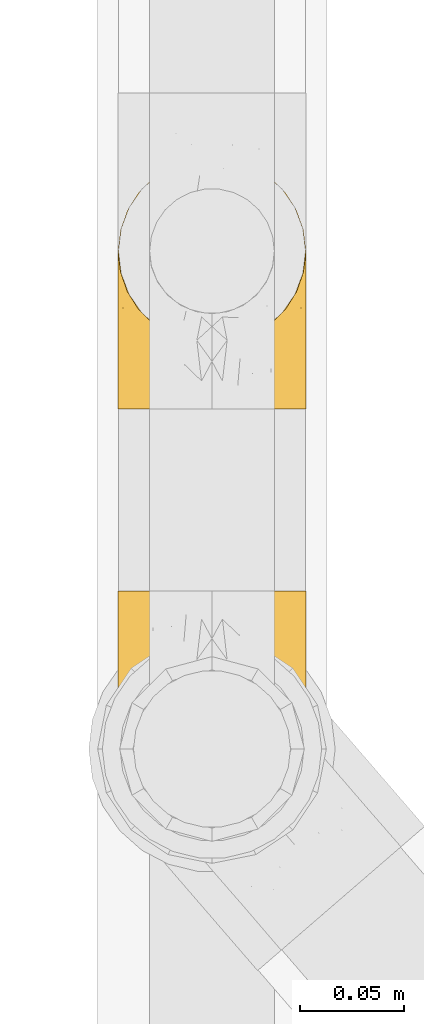
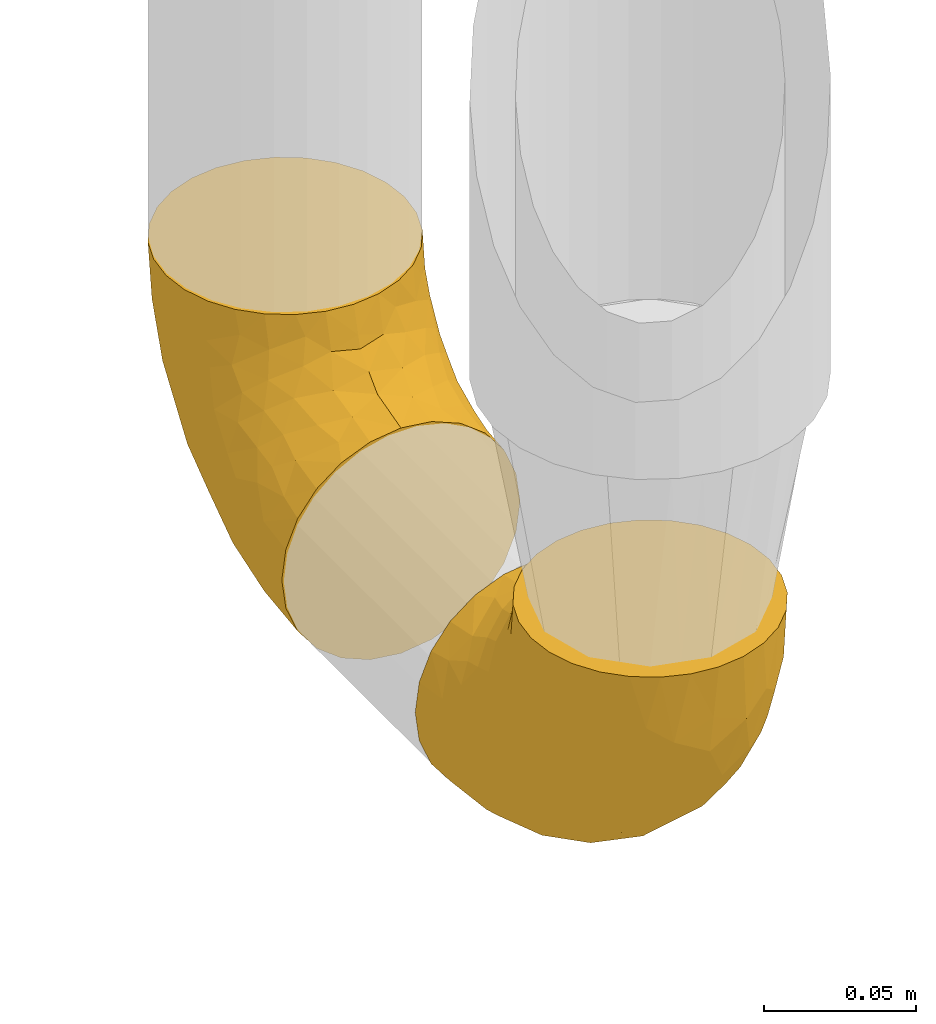
# One storey, part 202 of 827: 2 coverings.
"""IFC2X3 building model written with IfcOpenShell, lengths in millimetres."""

from ifc_helpers import new_model, entity, si_unit, converted_unit, derived_unit, direction, frame, origin, place, context, subcontext, project, spatial, faceted_brep, element, save


model = new_model("IFC2X3")

# Units and contexts
model_context = context("Model", 3, precision=0.01, world=origin(), true_north=direction((6.12303176911189e-17, 1.0)))
body_context = subcontext(model_context, "Body", "Model", "MODEL_VIEW")
ifc_project = project(units=[si_unit("LENGTHUNIT", "METRE", prefix="MILLI"), si_unit("AREAUNIT", "SQUARE_METRE"), si_unit("VOLUMEUNIT", "CUBIC_METRE"), converted_unit("PLANEANGLEUNIT", "DEGREE", entity("IfcRatioMeasure", 0.0174532925199433), si_unit("PLANEANGLEUNIT", "RADIAN"), dimensions=[0, 0, 0, 0, 0, 0, 0]), si_unit("MASSUNIT", "GRAM", prefix="KILO"), derived_unit("MASSDENSITYUNIT", [(si_unit("MASSUNIT", "GRAM", prefix="KILO"), 1), (si_unit("LENGTHUNIT", "METRE"), -3)]), derived_unit("MOMENTOFINERTIAUNIT", [(si_unit("LENGTHUNIT", "METRE"), 4)]), si_unit("TIMEUNIT", "SECOND"), si_unit("FREQUENCYUNIT", "HERTZ"), si_unit("THERMODYNAMICTEMPERATUREUNIT", "DEGREE_CELSIUS"), derived_unit("THERMALTRANSMITTANCEUNIT", [(si_unit("MASSUNIT", "GRAM", prefix="KILO"), 1), (si_unit("THERMODYNAMICTEMPERATUREUNIT", "KELVIN"), -1), (si_unit("TIMEUNIT", "SECOND"), -3)]), derived_unit("VOLUMETRICFLOWRATEUNIT", [(si_unit("LENGTHUNIT", "METRE"), 3), (si_unit("TIMEUNIT", "SECOND"), -1)]), derived_unit("MASSFLOWRATEUNIT", [(si_unit("MASSUNIT", "GRAM", prefix="KILO"), 1), (si_unit("TIMEUNIT", "SECOND"), -1)]), derived_unit("ROTATIONALFREQUENCYUNIT", [(si_unit("TIMEUNIT", "SECOND"), -1)]), si_unit("ELECTRICCURRENTUNIT", "AMPERE"), si_unit("ELECTRICVOLTAGEUNIT", "VOLT"), si_unit("POWERUNIT", "WATT"), si_unit("FORCEUNIT", "NEWTON", prefix="KILO"), si_unit("ILLUMINANCEUNIT", "LUX"), si_unit("LUMINOUSFLUXUNIT", "LUMEN"), si_unit("LUMINOUSINTENSITYUNIT", "CANDELA"), derived_unit("USERDEFINED", [(si_unit("MASSUNIT", "GRAM", prefix="KILO"), -1), (si_unit("LENGTHUNIT", "METRE"), -2), (si_unit("TIMEUNIT", "SECOND"), 3), (si_unit("LUMINOUSFLUXUNIT", "LUMEN"), 1)]), derived_unit("LINEARVELOCITYUNIT", [(si_unit("LENGTHUNIT", "METRE"), 1), (si_unit("TIMEUNIT", "SECOND"), -1)]), si_unit("PRESSUREUNIT", "PASCAL"), derived_unit("USERDEFINED", [(si_unit("LENGTHUNIT", "METRE"), -2), (si_unit("MASSUNIT", "GRAM", prefix="KILO"), 1), (si_unit("TIMEUNIT", "SECOND"), -2)]), derived_unit("LINEARFORCEUNIT", [(si_unit("MASSUNIT", "GRAM", prefix="KILO"), 1), (si_unit("LENGTHUNIT", "METRE"), 1), (si_unit("TIMEUNIT", "SECOND"), -2), (si_unit("LENGTHUNIT", "METRE"), -1)]), derived_unit("PLANARFORCEUNIT", [(si_unit("MASSUNIT", "GRAM", prefix="KILO"), 1), (si_unit("LENGTHUNIT", "METRE"), 1), (si_unit("TIMEUNIT", "SECOND"), -2), (si_unit("LENGTHUNIT", "METRE"), -2)])], contexts=[model_context])

# Site, building, storey
site_placement = place(None, origin())
site = spatial("IfcSite", under=ifc_project, at=site_placement, CompositionType="ELEMENT")
building_placement = place(site_placement, origin())
building = spatial("IfcBuilding", under=site, at=building_placement, CompositionType="ELEMENT")
storey_placement = place(building_placement, frame((0.0, 0.0, 28200.0)))
storey = spatial("IfcBuildingStorey", under=building, at=storey_placement, Name="08", CompositionType="ELEMENT", Elevation=28200.0)

# Coverings
covering_1_placement = place(storey_placement, frame((36582.9, 10433.46, 353.25)))
element("IfcCovering", 1, at=covering_1_placement, inside=storey, Name=":ADSK_", ObjectType=":ADSK_", PredefinedType="INSULATION", context=body_context, shape_type="Brep", body=[
    faceted_brep([(2.73, 36.69, 122.75), (6.07, 27.15, 122.75), (11.45, 18.59, 122.75), (18.6, 11.44, 122.75), (27.16, 6.06, 122.75), (36.7, 2.73, 122.75), (46.75, 1.6, 122.75), (56.8, 2.73, 122.75), (66.34, 6.07, 122.75), (74.9, 11.45, 122.75), (82.05, 18.6, 122.75), (87.43, 27.16, 122.75), (90.76, 36.7, 122.75), (91.9, 46.75, 122.75), (90.76, 56.8, 122.75), (87.42, 66.34, 122.75), (82.04, 74.9, 122.75), (74.89, 82.05, 122.75), (66.33, 87.43, 122.75), (56.79, 90.76, 122.75), (46.75, 91.9, 122.75), (36.69, 90.76, 122.75), (27.15, 87.42, 122.75), (18.59, 82.04, 122.75), (11.44, 74.89, 122.75), (6.06, 66.33, 122.75), (2.73, 56.79, 122.75), (1.6, 46.75, 122.75), (58.43, 122.75, 90.36), (69.32, 122.75, 85.85), (78.67, 122.75, 78.67), (85.85, 122.75, 69.32), (90.36, 122.75, 58.43), (91.9, 122.75, 46.75), (90.36, 122.75, 35.06), (85.85, 122.75, 24.17), (78.67, 122.75, 14.82), (69.32, 122.75, 7.64), (58.43, 122.75, 3.13), (46.75, 122.75, 1.6), (35.06, 122.75, 3.13), (24.17, 122.75, 7.64), (14.82, 122.75, 14.82), (7.64, 122.75, 24.17), (3.13, 122.75, 35.06), (1.6, 122.75, 46.75), (3.13, 122.75, 58.43), (7.64, 122.75, 69.32), (14.82, 122.75, 78.67), (24.17, 122.75, 85.85), (35.06, 122.75, 90.36), (46.75, 122.75, 91.9), (46.75, 24.73, 51.54), (38.29, 29.08, 47.17), (46.75, 38.13, 38.13), (46.75, 85.31, 7.52), (38.96, 93.59, 5.85), (46.75, 100.54, 5.11), (33.86, 63.54, 19.2), (31.42, 38.98, 38.98), (21.63, 50.71, 35.02), (30.84, 93.33, 8.21), (22.16, 75.2, 19.28), (20.56, 100.46, 12.19), (2.29, 41.6, 101.39), (7.18, 80.86, 34.43), (12.6, 94.87, 20.95), (14.0, 67.96, 30.74), (2.81, 52.16, 72.93), (6.65, 52.1, 56.64), (6.11, 36.74, 80.81), (16.62, 17.11, 93.43), (9.76, 23.24, 100.76), (12.46, 29.18, 74.27), (1.6, 52.53, 93.66), (1.6, 60.77, 81.33), (1.6, 69.01, 69.01), (2.46, 100.68, 40.87), (5.91, 103.79, 29.38), (36.97, 16.37, 67.05), (46.75, 7.52, 85.31), (33.09, 7.31, 93.68), (1.6, 93.66, 52.53), (1.6, 102.83, 50.71), (1.6, 112.01, 48.88), (25.62, 18.17, 72.77), (3.14, 71.97, 51.21), (23.92, 9.83, 101.18), (46.75, 5.11, 100.54), (13.58, 45.97, 48.74), (1.6, 48.88, 112.01), (1.6, 50.71, 102.83), (18.5, 22.83, 73.88), (46.75, 51.54, 24.73), (1.6, 81.33, 60.77), (4.96, 31.74, 103.08), (20.84, 32.48, 54.8), (46.75, 68.42, 16.13), (30.52, 25.33, 55.92), (46.75, 16.13, 68.42), (27.29, 92.29, 104.98), (36.89, 94.12, 108.58), (33.6, 100.97, 98.21), (2.54, 95.91, 61.56), (3.27, 107.9, 60.69), (16.85, 87.24, 100.0), (21.91, 95.46, 95.88), (13.5, 90.41, 90.81), (3.96, 74.17, 84.88), (3.52, 83.77, 73.29), (12.17, 76.72, 113.4), (18.93, 84.44, 109.8), (9.34, 76.42, 102.13), (3.12, 90.07, 67.29), (5.67, 99.69, 70.34), (2.51, 61.74, 95.15), (2.53, 58.16, 105.49), (8.35, 112.6, 71.5), (35.39, 110.45, 92.87), (46.75, 107.32, 96.03), (15.1, 108.48, 81.34), (5.27, 66.63, 107.44), (27.43, 115.23, 88.36), (24.89, 105.79, 90.43), (29.71, 89.6, 114.37), (5.07, 69.39, 98.41), (2.88, 66.99, 88.73), (9.69, 102.31, 76.89), (15.51, 99.54, 86.08), (2.27, 55.27, 112.64), (10.03, 82.03, 94.21), (46.75, 94.71, 112.22), (46.75, 96.03, 107.32), (8.83, 94.11, 79.95), (7.16, 84.21, 84.51), (46.75, 101.67, 101.67), (46.75, 112.22, 94.71), (78.39, 108.48, 81.34), (83.8, 102.31, 76.89), (77.97, 99.54, 86.08), (84.66, 94.11, 79.96), (58.1, 110.46, 92.87), (81.31, 76.74, 113.41), (91.9, 50.71, 102.83), (90.96, 58.17, 105.5), (91.22, 55.27, 112.64), (56.59, 94.12, 108.58), (66.18, 92.3, 104.98), (59.87, 100.98, 98.2), (88.42, 69.41, 98.4), (84.13, 76.44, 102.13), (88.22, 66.65, 107.44), (66.06, 115.24, 88.36), (91.9, 102.83, 50.71), (91.9, 112.01, 48.88), (83.44, 82.05, 94.22), (76.62, 87.25, 100.01), (85.14, 112.6, 71.5), (90.22, 107.9, 60.69), (91.9, 93.66, 52.53), (71.55, 95.48, 95.89), (63.77, 89.6, 114.37), (91.9, 60.77, 81.33), (91.9, 69.01, 69.01), (89.53, 74.17, 84.88), (91.9, 48.88, 112.01), (74.55, 84.45, 109.8), (90.95, 95.91, 61.56), (90.37, 90.07, 67.29), (91.9, 81.33, 60.77), (90.98, 61.75, 95.14), (89.97, 83.77, 73.29), (86.32, 84.21, 84.53), (91.9, 52.53, 93.66), (79.97, 90.42, 90.82), (90.61, 67.0, 88.73), (87.82, 99.69, 70.34), (68.6, 105.8, 90.43), (80.89, 94.87, 20.95), (86.31, 80.86, 34.43), (79.49, 67.95, 30.74), (71.33, 75.17, 19.29), (71.88, 50.65, 35.07), (90.35, 71.97, 51.21), (86.85, 52.08, 56.67), (72.67, 32.46, 54.85), (62.08, 38.98, 38.98), (87.58, 103.79, 29.38), (91.03, 100.68, 40.87), (59.62, 63.54, 19.2), (62.65, 93.32, 8.21), (54.53, 93.59, 5.85), (72.93, 100.44, 12.19), (90.68, 52.17, 72.93), (87.39, 36.75, 80.83), (91.2, 41.61, 101.39), (60.41, 7.31, 93.69), (76.88, 17.12, 93.43), (56.53, 16.37, 67.04), (83.74, 23.26, 100.76), (67.88, 18.17, 72.78), (62.99, 25.33, 55.93), (69.58, 9.84, 101.18), (81.04, 29.19, 74.27), (75.0, 22.84, 73.89), (88.53, 31.75, 103.09), (79.93, 45.96, 48.78), (55.21, 29.07, 47.19)], [[[0, 1, 2, 3, 4, 5, 6, 7, 8, 9, 10, 11, 12, 13, 14, 15, 16, 17, 18, 19, 20, 21, 22, 23, 24, 25, 26, 27]], [[28, 29, 30, 31, 32, 33, 34, 35, 36, 37, 38, 39, 40, 41, 42, 43, 44, 45, 46, 47, 48, 49, 50, 51]], [[52, 53, 54]], [[55, 56, 57]], [[58, 59, 60]], [[61, 62, 63]], [[27, 64, 0]], [[65, 66, 67]], [[41, 40, 61]], [[68, 69, 70]], [[66, 43, 42]], [[63, 42, 41]], [[71, 72, 73]], [[72, 2, 1]], [[68, 74, 75, 76]], [[45, 44, 77]], [[43, 78, 44]], [[79, 80, 81]], [[77, 82, 83, 84, 45]], [[79, 81, 85]], [[71, 2, 72]], [[65, 86, 77]], [[4, 81, 5]], [[66, 65, 78]], [[4, 3, 87]], [[81, 88, 5]], [[63, 66, 42]], [[68, 70, 64]], [[67, 60, 89]], [[71, 3, 2]], [[64, 27, 90, 91, 74]], [[92, 71, 73]], [[40, 57, 56]], [[59, 93, 54]], [[86, 76, 94, 82]], [[1, 0, 95]], [[58, 62, 61]], [[60, 96, 89]], [[85, 81, 87]], [[56, 97, 58]], [[65, 67, 69]], [[87, 81, 4]], [[67, 89, 69]], [[61, 63, 41]], [[95, 72, 1]], [[73, 72, 70]], [[69, 73, 70]], [[73, 89, 96]], [[3, 71, 87]], [[85, 87, 71]], [[58, 61, 56]], [[59, 58, 93]], [[76, 86, 68]], [[69, 89, 73]], [[68, 86, 69]], [[65, 69, 86]], [[68, 64, 74]], [[95, 64, 70]], [[98, 79, 85]], [[79, 52, 99, 80]], [[66, 62, 67]], [[62, 58, 60]], [[62, 60, 67]], [[59, 98, 96]], [[59, 96, 60]], [[96, 85, 92]], [[88, 81, 80]], [[88, 6, 5]], [[66, 63, 62]], [[64, 95, 0]], [[72, 95, 70]], [[77, 44, 78]], [[86, 82, 77]], [[40, 39, 57]], [[96, 98, 85]], [[40, 56, 61]], [[66, 78, 43]], [[77, 78, 65]], [[79, 98, 53]], [[96, 92, 73]], [[85, 71, 92]], [[97, 56, 55]], [[97, 93, 58]], [[53, 98, 59]], [[54, 53, 59]], [[79, 53, 52]], [[100, 101, 102]], [[46, 45, 84, 83]], [[103, 104, 82]], [[82, 104, 83]], [[105, 106, 107]], [[108, 109, 76]], [[110, 111, 112]], [[103, 113, 114]], [[115, 74, 116]], [[48, 47, 117]], [[118, 102, 119]], [[49, 48, 120]], [[74, 91, 116]], [[116, 121, 115]], [[49, 122, 50]], [[123, 106, 102]], [[124, 111, 22]], [[125, 126, 115]], [[23, 22, 111]], [[24, 110, 121]], [[120, 127, 128]], [[90, 26, 129]], [[27, 26, 90]], [[121, 125, 115]], [[24, 121, 25]], [[130, 105, 107]], [[129, 25, 116]], [[21, 20, 131]], [[120, 123, 122]], [[112, 105, 130]], [[50, 118, 51]], [[21, 124, 22]], [[101, 131, 132]], [[117, 120, 48]], [[24, 23, 110]], [[127, 114, 133]], [[75, 108, 76]], [[107, 134, 130]], [[133, 114, 113]], [[129, 116, 91]], [[25, 121, 116]], [[121, 112, 125]], [[75, 74, 115]], [[101, 135, 102]], [[131, 101, 21]], [[101, 100, 124]], [[128, 127, 133]], [[119, 136, 51, 118]], [[104, 47, 46]], [[83, 104, 46]], [[117, 104, 114]], [[101, 124, 21]], [[111, 124, 100]], [[102, 118, 123]], [[133, 134, 107]], [[111, 110, 23]], [[114, 104, 103]], [[94, 76, 109]], [[121, 110, 112]], [[122, 118, 50]], [[134, 109, 108]], [[133, 107, 128]], [[112, 108, 125]], [[126, 125, 108]], [[108, 75, 126]], [[75, 115, 126]], [[109, 134, 133]], [[130, 108, 112]], [[108, 130, 134]], [[105, 112, 111]], [[111, 100, 105]], [[106, 105, 100]], [[102, 106, 100]], [[128, 106, 123]], [[90, 129, 91]], [[25, 129, 26]], [[104, 117, 47]], [[117, 114, 127]], [[82, 94, 103]], [[113, 94, 109]], [[94, 113, 103]], [[133, 113, 109]], [[106, 128, 107]], [[123, 120, 128]], [[120, 122, 49]], [[118, 122, 123]], [[135, 101, 132]], [[135, 119, 102]], [[117, 127, 120]], [[30, 29, 137]], [[138, 139, 140]], [[51, 136, 119, 141]], [[142, 17, 16]], [[143, 144, 145]], [[146, 147, 148]], [[149, 150, 151]], [[152, 29, 28]], [[33, 32, 153, 154]], [[150, 155, 156]], [[157, 31, 30]], [[153, 158, 159]], [[29, 152, 137]], [[148, 141, 119]], [[156, 160, 147]], [[148, 135, 146]], [[137, 138, 157]], [[19, 161, 146]], [[162, 163, 164]], [[14, 13, 165]], [[153, 32, 158]], [[147, 161, 166]], [[18, 17, 166]], [[167, 168, 169]], [[166, 150, 156]], [[151, 150, 142]], [[151, 170, 149]], [[151, 16, 15]], [[171, 140, 172]], [[165, 143, 145]], [[173, 170, 144]], [[142, 166, 17]], [[19, 131, 20]], [[144, 170, 151]], [[18, 161, 19]], [[173, 144, 143]], [[140, 139, 174]], [[171, 164, 163]], [[164, 172, 155]], [[151, 15, 144]], [[145, 15, 14]], [[173, 162, 170]], [[149, 175, 164]], [[19, 146, 131]], [[132, 131, 146]], [[160, 148, 147]], [[159, 158, 167]], [[135, 132, 146]], [[158, 32, 31]], [[157, 158, 31]], [[167, 158, 176]], [[166, 161, 18]], [[146, 161, 147]], [[148, 177, 141]], [[171, 168, 140]], [[171, 163, 169]], [[151, 142, 16]], [[166, 142, 150]], [[152, 141, 177]], [[51, 141, 28]], [[138, 140, 176]], [[172, 140, 174]], [[175, 149, 170]], [[164, 150, 149]], [[170, 162, 175]], [[162, 164, 175]], [[155, 172, 174]], [[171, 172, 164]], [[155, 174, 156]], [[164, 155, 150]], [[160, 156, 174]], [[147, 166, 156]], [[139, 160, 174]], [[148, 160, 177]], [[15, 145, 144]], [[165, 145, 14]], [[137, 157, 30]], [[158, 157, 176]], [[168, 167, 176]], [[169, 159, 167]], [[140, 168, 176]], [[169, 168, 171]], [[137, 177, 139]], [[160, 139, 177]], [[141, 152, 28]], [[137, 152, 177]], [[148, 119, 135]], [[157, 138, 176]], [[139, 138, 137]], [[178, 179, 180]], [[181, 180, 182]], [[179, 183, 184]], [[185, 186, 182]], [[187, 188, 179]], [[188, 33, 154, 153, 159]], [[181, 189, 190]], [[35, 34, 187]], [[191, 38, 190]], [[192, 178, 181]], [[179, 184, 180]], [[192, 190, 37]], [[37, 190, 38]], [[36, 35, 178]], [[54, 93, 186]], [[35, 187, 178]], [[193, 194, 184]], [[195, 173, 143, 165, 13]], [[195, 193, 173]], [[193, 163, 162, 173]], [[13, 12, 195]], [[8, 7, 196]], [[9, 197, 10]], [[198, 80, 99, 52]], [[196, 7, 88]], [[197, 199, 10]], [[182, 189, 181]], [[200, 198, 201]], [[200, 196, 198]], [[9, 8, 202]], [[194, 199, 203]], [[192, 37, 36]], [[80, 196, 88]], [[183, 159, 169, 163]], [[188, 34, 33]], [[202, 200, 197]], [[185, 203, 204]], [[202, 8, 196]], [[10, 199, 11]], [[12, 11, 205]], [[38, 191, 57]], [[189, 97, 191]], [[203, 199, 197]], [[205, 199, 194]], [[204, 203, 197]], [[184, 203, 206]], [[200, 202, 196]], [[197, 9, 202]], [[207, 54, 186]], [[97, 55, 191]], [[194, 203, 184]], [[183, 163, 193]], [[184, 206, 180]], [[183, 193, 184]], [[205, 195, 12]], [[193, 195, 194]], [[80, 198, 196]], [[207, 186, 201]], [[182, 180, 206]], [[181, 178, 180]], [[185, 182, 206]], [[182, 186, 189]], [[203, 185, 206]], [[185, 200, 201]], [[7, 6, 88]], [[178, 192, 36]], [[190, 192, 181]], [[199, 205, 11]], [[195, 205, 194]], [[159, 183, 188]], [[179, 188, 183]], [[57, 191, 55]], [[57, 39, 38]], [[189, 191, 190]], [[188, 187, 34]], [[178, 187, 179]], [[186, 93, 189]], [[197, 200, 204]], [[185, 204, 200]], [[189, 93, 97]], [[207, 198, 52]], [[185, 201, 186]], [[198, 207, 201]], [[54, 207, 52]]]),
])
covering_2_placement = place(storey_placement, frame((36582.9, 10642.13, 353.25)))
element("IfcCovering", 2, at=covering_2_placement, inside=storey, Name=":ADSK_", ObjectType=":ADSK_", PredefinedType="INSULATION", context=body_context, shape_type="Brep", body=[
    faceted_brep([(90.76, 87.65, 122.75), (87.42, 97.19, 122.75), (82.04, 105.75, 122.75), (74.89, 112.9, 122.75), (66.33, 118.28, 122.75), (56.79, 121.61, 122.75), (46.75, 122.75, 122.75), (36.69, 121.61, 122.75), (27.15, 118.27, 122.75), (18.59, 112.89, 122.75), (11.44, 105.74, 122.75), (6.06, 97.18, 122.75), (2.73, 87.64, 122.75), (1.6, 77.6, 122.75), (2.73, 67.54, 122.75), (6.07, 58.0, 122.75), (11.45, 49.44, 122.75), (18.6, 42.29, 122.75), (27.16, 36.91, 122.75), (36.7, 33.58, 122.75), (46.75, 32.45, 122.75), (56.8, 33.58, 122.75), (66.34, 36.92, 122.75), (74.9, 42.3, 122.75), (82.05, 49.45, 122.75), (87.43, 58.01, 122.75), (90.76, 67.55, 122.75), (91.9, 77.6, 122.75), (35.06, 1.6, 90.36), (24.17, 1.6, 85.85), (14.82, 1.6, 78.67), (7.64, 1.6, 69.32), (3.13, 1.6, 58.43), (1.6, 1.6, 46.75), (3.13, 1.6, 35.06), (7.64, 1.6, 24.17), (14.82, 1.6, 14.82), (24.17, 1.6, 7.64), (35.06, 1.6, 3.13), (46.75, 1.6, 1.6), (58.43, 1.6, 3.13), (69.32, 1.6, 7.64), (78.67, 1.6, 14.82), (85.85, 1.6, 24.17), (90.36, 1.6, 35.06), (91.9, 1.6, 46.75), (90.36, 1.6, 58.43), (85.85, 1.6, 69.32), (78.67, 1.6, 78.67), (69.32, 1.6, 85.85), (58.43, 1.6, 90.36), (46.75, 1.6, 91.9), (46.75, 99.61, 51.54), (55.2, 95.26, 47.17), (46.75, 86.21, 38.13), (46.75, 39.03, 7.52), (54.53, 30.75, 5.85), (46.75, 23.8, 5.11), (59.63, 60.8, 19.2), (62.07, 85.37, 38.98), (71.86, 73.64, 35.02), (62.65, 31.01, 8.21), (71.33, 49.14, 19.28), (72.93, 23.88, 12.19), (91.2, 82.74, 101.39), (86.31, 43.48, 34.43), (80.89, 29.47, 20.95), (79.49, 56.38, 30.74), (90.68, 72.18, 72.93), (86.84, 72.24, 56.64), (87.38, 87.6, 80.81), (76.87, 107.24, 93.43), (83.73, 101.1, 100.76), (81.03, 95.16, 74.27), (91.9, 71.81, 93.66), (91.9, 63.57, 81.33), (91.9, 55.34, 69.01), (91.03, 23.66, 40.87), (87.58, 20.55, 29.38), (56.52, 107.97, 67.05), (46.75, 116.82, 85.31), (60.4, 117.03, 93.68), (91.9, 30.68, 52.53), (91.9, 21.51, 50.71), (91.9, 12.33, 48.88), (67.87, 106.17, 72.77), (90.35, 52.37, 51.21), (69.57, 114.51, 101.18), (46.75, 119.23, 100.54), (79.91, 78.37, 48.74), (91.9, 75.46, 112.01), (91.9, 73.63, 102.83), (74.99, 101.51, 73.88), (46.75, 72.81, 24.73), (91.9, 43.01, 60.77), (88.53, 92.6, 103.08), (72.65, 91.86, 54.8), (46.75, 55.92, 16.13), (62.97, 99.01, 55.92), (46.75, 108.21, 68.42), (66.2, 32.05, 104.98), (56.6, 30.22, 108.58), (59.89, 23.37, 98.21), (90.95, 28.43, 61.56), (90.22, 16.44, 60.69), (76.64, 37.1, 100.0), (71.58, 28.88, 95.88), (79.99, 33.93, 90.81), (89.54, 50.17, 84.88), (89.97, 40.57, 73.29), (81.32, 47.62, 113.4), (74.56, 39.9, 109.8), (84.15, 47.92, 102.13), (90.37, 34.27, 67.29), (87.82, 24.65, 70.34), (90.98, 62.6, 95.15), (90.96, 66.18, 105.49), (85.14, 11.74, 71.5), (58.11, 13.89, 92.87), (46.75, 17.02, 96.03), (78.39, 15.86, 81.34), (88.22, 57.71, 107.44), (66.06, 9.11, 88.36), (68.6, 18.55, 90.43), (63.78, 34.74, 114.37), (88.42, 54.95, 98.41), (90.61, 57.35, 88.73), (83.8, 22.03, 76.89), (77.98, 24.8, 86.08), (91.22, 69.07, 112.64), (83.46, 42.31, 94.21), (46.75, 29.63, 112.22), (46.75, 28.31, 107.32), (84.66, 30.23, 79.95), (86.33, 40.13, 84.51), (46.75, 22.67, 101.67), (46.75, 12.12, 94.71), (15.1, 15.86, 81.34), (9.69, 22.03, 76.89), (15.52, 24.8, 86.08), (8.83, 30.23, 79.96), (35.39, 13.88, 92.87), (12.18, 47.61, 113.41), (1.6, 73.63, 102.83), (2.53, 66.17, 105.5), (2.27, 69.07, 112.64), (36.9, 30.22, 108.58), (27.31, 32.04, 104.98), (33.62, 23.36, 98.2), (5.07, 54.93, 98.4), (9.36, 47.91, 102.13), (5.27, 57.69, 107.44), (27.43, 9.1, 88.36), (1.6, 21.51, 50.71), (1.6, 12.33, 48.88), (10.05, 42.29, 94.22), (16.87, 37.09, 100.01), (8.35, 11.74, 71.5), (3.27, 16.44, 60.69), (1.6, 30.68, 52.53), (21.94, 28.86, 95.89), (29.72, 34.74, 114.37), (1.6, 63.57, 81.33), (1.6, 55.34, 69.01), (3.96, 50.17, 84.88), (1.6, 75.46, 112.01), (18.95, 39.89, 109.8), (2.54, 28.43, 61.56), (3.12, 34.27, 67.29), (1.6, 43.01, 60.77), (2.51, 62.59, 95.14), (3.52, 40.57, 73.29), (7.17, 40.13, 84.53), (1.6, 71.81, 93.66), (13.52, 33.92, 90.82), (2.88, 57.34, 88.73), (5.67, 24.65, 70.34), (24.89, 18.54, 90.43), (12.6, 29.47, 20.95), (7.18, 43.48, 34.43), (14.0, 56.4, 30.74), (22.16, 49.17, 19.29), (21.61, 73.69, 35.07), (3.14, 52.37, 51.21), (6.65, 72.26, 56.67), (20.82, 91.88, 54.85), (31.41, 85.36, 38.98), (5.91, 20.55, 29.38), (2.46, 23.66, 40.87), (33.87, 60.8, 19.2), (30.84, 31.02, 8.21), (38.96, 30.75, 5.85), (20.56, 23.9, 12.19), (2.81, 72.17, 72.93), (6.1, 87.59, 80.83), (2.29, 82.74, 101.39), (33.08, 117.03, 93.69), (16.61, 107.23, 93.43), (36.96, 107.97, 67.04), (9.75, 101.08, 100.76), (25.61, 106.17, 72.78), (30.5, 99.01, 55.93), (23.91, 114.5, 101.18), (12.45, 95.15, 74.27), (18.49, 101.5, 73.89), (4.96, 92.59, 103.09), (13.56, 78.38, 48.78), (38.28, 95.27, 47.19)], [[[0, 1, 2, 3, 4, 5, 6, 7, 8, 9, 10, 11, 12, 13, 14, 15, 16, 17, 18, 19, 20, 21, 22, 23, 24, 25, 26, 27]], [[28, 29, 30, 31, 32, 33, 34, 35, 36, 37, 38, 39, 40, 41, 42, 43, 44, 45, 46, 47, 48, 49, 50, 51]], [[52, 53, 54]], [[55, 56, 57]], [[58, 59, 60]], [[61, 62, 63]], [[27, 64, 0]], [[65, 66, 67]], [[41, 40, 61]], [[68, 69, 70]], [[66, 43, 42]], [[63, 42, 41]], [[71, 72, 73]], [[72, 2, 1]], [[68, 74, 75, 76]], [[45, 44, 77]], [[43, 78, 44]], [[79, 80, 81]], [[77, 82, 83, 84, 45]], [[79, 81, 85]], [[71, 2, 72]], [[65, 86, 77]], [[4, 81, 5]], [[66, 65, 78]], [[4, 3, 87]], [[81, 88, 5]], [[63, 66, 42]], [[68, 70, 64]], [[67, 60, 89]], [[71, 3, 2]], [[64, 27, 90, 91, 74]], [[92, 71, 73]], [[40, 57, 56]], [[59, 93, 54]], [[86, 76, 94, 82]], [[1, 0, 95]], [[58, 62, 61]], [[60, 96, 89]], [[85, 81, 87]], [[56, 97, 58]], [[65, 67, 69]], [[87, 81, 4]], [[67, 89, 69]], [[61, 63, 41]], [[95, 72, 1]], [[73, 72, 70]], [[69, 73, 70]], [[73, 89, 96]], [[3, 71, 87]], [[85, 87, 71]], [[58, 61, 56]], [[59, 58, 93]], [[76, 86, 68]], [[69, 89, 73]], [[68, 86, 69]], [[65, 69, 86]], [[68, 64, 74]], [[95, 64, 70]], [[98, 79, 85]], [[79, 52, 99, 80]], [[66, 62, 67]], [[62, 58, 60]], [[62, 60, 67]], [[59, 98, 96]], [[59, 96, 60]], [[96, 85, 92]], [[88, 81, 80]], [[88, 6, 5]], [[66, 63, 62]], [[64, 95, 0]], [[72, 95, 70]], [[77, 44, 78]], [[86, 82, 77]], [[40, 39, 57]], [[96, 98, 85]], [[40, 56, 61]], [[66, 78, 43]], [[77, 78, 65]], [[79, 98, 53]], [[96, 92, 73]], [[85, 71, 92]], [[97, 56, 55]], [[97, 93, 58]], [[53, 98, 59]], [[54, 53, 59]], [[79, 53, 52]], [[100, 101, 102]], [[46, 45, 84, 83]], [[103, 104, 82]], [[82, 104, 83]], [[105, 106, 107]], [[108, 109, 76]], [[110, 111, 112]], [[103, 113, 114]], [[115, 74, 116]], [[48, 47, 117]], [[118, 102, 119]], [[49, 48, 120]], [[74, 91, 116]], [[116, 121, 115]], [[49, 122, 50]], [[123, 106, 102]], [[124, 111, 22]], [[125, 126, 115]], [[23, 22, 111]], [[24, 110, 121]], [[120, 127, 128]], [[90, 26, 129]], [[27, 26, 90]], [[121, 125, 115]], [[24, 121, 25]], [[130, 105, 107]], [[129, 25, 116]], [[21, 20, 131]], [[120, 123, 122]], [[112, 105, 130]], [[50, 118, 51]], [[21, 124, 22]], [[101, 131, 132]], [[117, 120, 48]], [[24, 23, 110]], [[127, 114, 133]], [[75, 108, 76]], [[107, 134, 130]], [[133, 114, 113]], [[129, 116, 91]], [[25, 121, 116]], [[121, 112, 125]], [[75, 74, 115]], [[101, 135, 102]], [[131, 101, 21]], [[101, 100, 124]], [[128, 127, 133]], [[119, 136, 51, 118]], [[104, 47, 46]], [[83, 104, 46]], [[117, 104, 114]], [[101, 124, 21]], [[111, 124, 100]], [[102, 118, 123]], [[133, 134, 107]], [[111, 110, 23]], [[114, 104, 103]], [[94, 76, 109]], [[121, 110, 112]], [[122, 118, 50]], [[134, 109, 108]], [[133, 107, 128]], [[112, 108, 125]], [[126, 125, 108]], [[108, 75, 126]], [[75, 115, 126]], [[109, 134, 133]], [[130, 108, 112]], [[108, 130, 134]], [[105, 112, 111]], [[111, 100, 105]], [[106, 105, 100]], [[102, 106, 100]], [[128, 106, 123]], [[90, 129, 91]], [[25, 129, 26]], [[104, 117, 47]], [[117, 114, 127]], [[82, 94, 103]], [[113, 94, 109]], [[94, 113, 103]], [[133, 113, 109]], [[106, 128, 107]], [[123, 120, 128]], [[120, 122, 49]], [[118, 122, 123]], [[135, 101, 132]], [[135, 119, 102]], [[117, 127, 120]], [[30, 29, 137]], [[138, 139, 140]], [[51, 136, 119, 141]], [[142, 17, 16]], [[143, 144, 145]], [[146, 147, 148]], [[149, 150, 151]], [[152, 29, 28]], [[33, 32, 153, 154]], [[150, 155, 156]], [[157, 31, 30]], [[153, 158, 159]], [[29, 152, 137]], [[148, 141, 119]], [[156, 160, 147]], [[148, 135, 146]], [[137, 138, 157]], [[19, 161, 146]], [[162, 163, 164]], [[14, 13, 165]], [[153, 32, 158]], [[147, 161, 166]], [[18, 17, 166]], [[167, 168, 169]], [[166, 150, 156]], [[151, 150, 142]], [[151, 170, 149]], [[151, 16, 15]], [[171, 140, 172]], [[165, 143, 145]], [[173, 170, 144]], [[142, 166, 17]], [[19, 131, 20]], [[144, 170, 151]], [[18, 161, 19]], [[173, 144, 143]], [[140, 139, 174]], [[171, 164, 163]], [[164, 172, 155]], [[151, 15, 144]], [[145, 15, 14]], [[173, 162, 170]], [[149, 175, 164]], [[19, 146, 131]], [[132, 131, 146]], [[160, 148, 147]], [[159, 158, 167]], [[135, 132, 146]], [[158, 32, 31]], [[157, 158, 31]], [[167, 158, 176]], [[166, 161, 18]], [[146, 161, 147]], [[148, 177, 141]], [[171, 168, 140]], [[171, 163, 169]], [[151, 142, 16]], [[166, 142, 150]], [[152, 141, 177]], [[51, 141, 28]], [[138, 140, 176]], [[172, 140, 174]], [[175, 149, 170]], [[164, 150, 149]], [[170, 162, 175]], [[162, 164, 175]], [[155, 172, 174]], [[171, 172, 164]], [[155, 174, 156]], [[164, 155, 150]], [[160, 156, 174]], [[147, 166, 156]], [[139, 160, 174]], [[148, 160, 177]], [[15, 145, 144]], [[165, 145, 14]], [[137, 157, 30]], [[158, 157, 176]], [[168, 167, 176]], [[169, 159, 167]], [[140, 168, 176]], [[169, 168, 171]], [[137, 177, 139]], [[160, 139, 177]], [[141, 152, 28]], [[137, 152, 177]], [[148, 119, 135]], [[157, 138, 176]], [[139, 138, 137]], [[178, 179, 180]], [[181, 180, 182]], [[179, 183, 184]], [[185, 186, 182]], [[187, 188, 179]], [[188, 33, 154, 153, 159]], [[181, 189, 190]], [[35, 34, 187]], [[191, 38, 190]], [[192, 178, 181]], [[179, 184, 180]], [[192, 190, 37]], [[37, 190, 38]], [[36, 35, 178]], [[54, 93, 186]], [[35, 187, 178]], [[193, 194, 184]], [[195, 173, 143, 165, 13]], [[195, 193, 173]], [[193, 163, 162, 173]], [[13, 12, 195]], [[8, 7, 196]], [[9, 197, 10]], [[198, 80, 99, 52]], [[196, 7, 88]], [[197, 199, 10]], [[182, 189, 181]], [[200, 198, 201]], [[200, 196, 198]], [[9, 8, 202]], [[194, 199, 203]], [[192, 37, 36]], [[80, 196, 88]], [[183, 159, 169, 163]], [[188, 34, 33]], [[202, 200, 197]], [[185, 203, 204]], [[202, 8, 196]], [[10, 199, 11]], [[12, 11, 205]], [[38, 191, 57]], [[189, 97, 191]], [[203, 199, 197]], [[205, 199, 194]], [[204, 203, 197]], [[184, 203, 206]], [[200, 202, 196]], [[197, 9, 202]], [[207, 54, 186]], [[97, 55, 191]], [[194, 203, 184]], [[183, 163, 193]], [[184, 206, 180]], [[183, 193, 184]], [[205, 195, 12]], [[193, 195, 194]], [[80, 198, 196]], [[207, 186, 201]], [[182, 180, 206]], [[181, 178, 180]], [[185, 182, 206]], [[182, 186, 189]], [[203, 185, 206]], [[185, 200, 201]], [[7, 6, 88]], [[178, 192, 36]], [[190, 192, 181]], [[199, 205, 11]], [[195, 205, 194]], [[159, 183, 188]], [[179, 188, 183]], [[57, 191, 55]], [[57, 39, 38]], [[189, 191, 190]], [[188, 187, 34]], [[178, 187, 179]], [[186, 93, 189]], [[197, 200, 204]], [[185, 204, 200]], [[189, 93, 97]], [[207, 198, 52]], [[185, 201, 186]], [[198, 207, 201]], [[54, 207, 52]]]),
])

save(model, "model.ifc")
